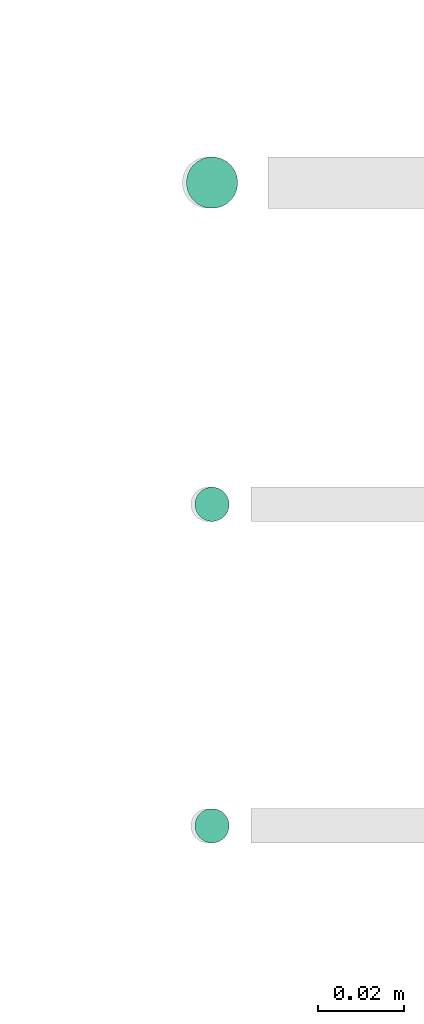
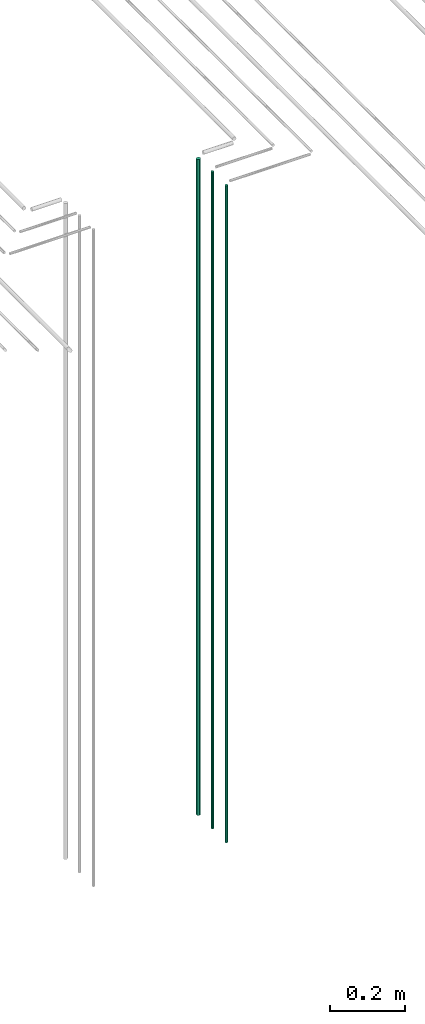
# One storey, part 60 of 331: 3 flow segments.
"""IFC2X3 building model written with IfcOpenShell, lengths in millimetres."""

from ifc_helpers import new_model, entity, si_unit, converted_unit, derived_unit, direction, frame, origin, origin_2d_with_axis, place, context, subcontext, project, spatial, circle, extrude, type_object, element, save


model = new_model("IFC2X3")

# Units and contexts
model_context = context("Model", 3, precision=0.01, world=origin(), true_north=direction((6.12303176911189e-17, 1.0)))
body_context = subcontext(model_context, "Body", "Model", "MODEL_VIEW")
ifc_project = project(units=[si_unit("LENGTHUNIT", "METRE", prefix="MILLI"), si_unit("AREAUNIT", "SQUARE_METRE"), si_unit("VOLUMEUNIT", "CUBIC_METRE"), converted_unit("PLANEANGLEUNIT", "DEGREE", entity("IfcRatioMeasure", 0.0174532925199433), si_unit("PLANEANGLEUNIT", "RADIAN"), dimensions=[0, 0, 0, 0, 0, 0, 0]), si_unit("MASSUNIT", "GRAM", prefix="KILO"), derived_unit("MASSDENSITYUNIT", [(si_unit("MASSUNIT", "GRAM", prefix="KILO"), 1), (si_unit("LENGTHUNIT", "METRE"), -3)]), derived_unit("MOMENTOFINERTIAUNIT", [(si_unit("LENGTHUNIT", "METRE"), 4)]), si_unit("TIMEUNIT", "SECOND"), si_unit("FREQUENCYUNIT", "HERTZ"), si_unit("THERMODYNAMICTEMPERATUREUNIT", "DEGREE_CELSIUS"), derived_unit("THERMALTRANSMITTANCEUNIT", [(si_unit("MASSUNIT", "GRAM", prefix="KILO"), 1), (si_unit("THERMODYNAMICTEMPERATUREUNIT", "KELVIN"), -1), (si_unit("TIMEUNIT", "SECOND"), -3)]), derived_unit("VOLUMETRICFLOWRATEUNIT", [(si_unit("LENGTHUNIT", "METRE"), 3), (si_unit("TIMEUNIT", "SECOND"), -1)]), derived_unit("MASSFLOWRATEUNIT", [(si_unit("MASSUNIT", "GRAM", prefix="KILO"), 1), (si_unit("TIMEUNIT", "SECOND"), -1)]), derived_unit("ROTATIONALFREQUENCYUNIT", [(si_unit("TIMEUNIT", "SECOND"), -1)]), si_unit("ELECTRICCURRENTUNIT", "AMPERE"), si_unit("ELECTRICVOLTAGEUNIT", "VOLT"), si_unit("POWERUNIT", "WATT"), si_unit("FORCEUNIT", "NEWTON", prefix="KILO"), si_unit("ILLUMINANCEUNIT", "LUX"), si_unit("LUMINOUSFLUXUNIT", "LUMEN"), si_unit("LUMINOUSINTENSITYUNIT", "CANDELA"), derived_unit("USERDEFINED", [(si_unit("MASSUNIT", "GRAM", prefix="KILO"), -1), (si_unit("LENGTHUNIT", "METRE"), -2), (si_unit("TIMEUNIT", "SECOND"), 3), (si_unit("LUMINOUSFLUXUNIT", "LUMEN"), 1)]), derived_unit("LINEARVELOCITYUNIT", [(si_unit("LENGTHUNIT", "METRE"), 1), (si_unit("TIMEUNIT", "SECOND"), -1)]), si_unit("PRESSUREUNIT", "PASCAL"), derived_unit("USERDEFINED", [(si_unit("LENGTHUNIT", "METRE"), -2), (si_unit("MASSUNIT", "GRAM", prefix="KILO"), 1), (si_unit("TIMEUNIT", "SECOND"), -2)]), derived_unit("LINEARFORCEUNIT", [(si_unit("MASSUNIT", "GRAM", prefix="KILO"), 1), (si_unit("LENGTHUNIT", "METRE"), 1), (si_unit("TIMEUNIT", "SECOND"), -2), (si_unit("LENGTHUNIT", "METRE"), -1)]), derived_unit("PLANARFORCEUNIT", [(si_unit("MASSUNIT", "GRAM", prefix="KILO"), 1), (si_unit("LENGTHUNIT", "METRE"), 1), (si_unit("TIMEUNIT", "SECOND"), -2), (si_unit("LENGTHUNIT", "METRE"), -2)])], contexts=[model_context])

# Site, building, storey
site_placement = place(None, frame((0.0, -0.00077364408347762, 0.0)))
site = spatial("IfcSite", under=ifc_project, at=site_placement, CompositionType="ELEMENT")
building_placement = place(site_placement, origin())
building = spatial("IfcBuilding", under=site, at=building_placement, CompositionType="ELEMENT")
storey_placement = place(building_placement, origin())
storey = spatial("IfcBuildingStorey", under=building, at=storey_placement, CompositionType="ELEMENT", Elevation=0.0)

# Flow segments
pipe_segment_type = type_object("IfcPipeSegmentType", PredefinedType="NOTDEFINED")
flow_segment_placement = place(storey_placement, frame((53569.1379388917, 3883.89349484363, 12990.0)))
element("IfcFlowSegment", 1, at=flow_segment_placement, inside=storey, type_object=pipe_segment_type, context=body_context, shape_type="SweptSolid", body=[
    extrude(circle(Radius=6.0, at=origin_2d_with_axis()), frame((7.59527223591454, 7.59527223591616, 0.0)), (0.0, 0.0, 1.0), 2146.0),
])
for number, where in (
    (2, (53571.1379388917, 3735.89349484356, 12990.0)),
    (3, (53571.1379388917, 3810.89349484379, 12990.0)),
):
    element("IfcFlowSegment", number, at=place(storey_placement, frame(where)), inside=storey, type_object=pipe_segment_type, context=body_context, shape_type="SweptSolid", body=[
        extrude(circle(Radius=4.0, at=origin_2d_with_axis()), frame((5.59527223591499, 5.59527223591607, 0.0)), (0.0, 0.0, 1.0), 2150.00000000001),
    ])

save(model, "model.ifc")
